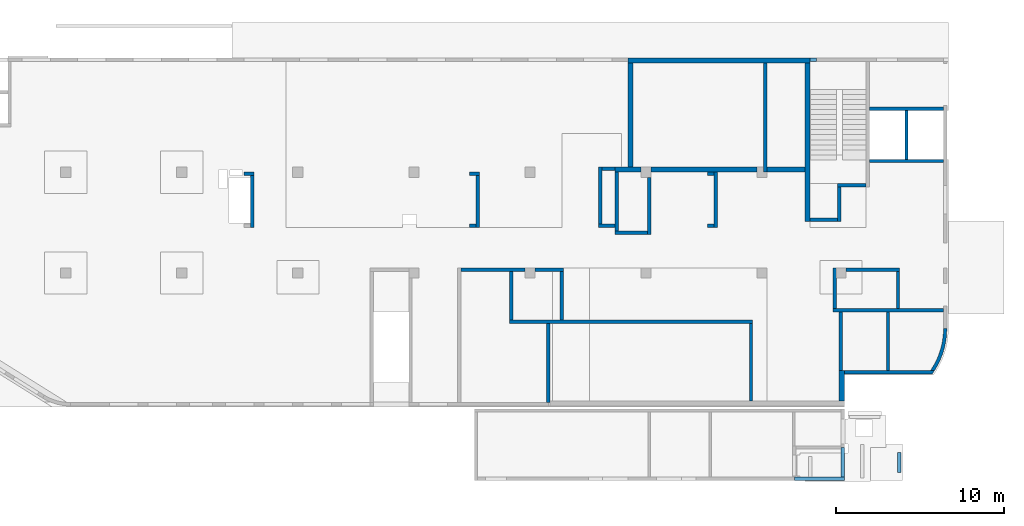
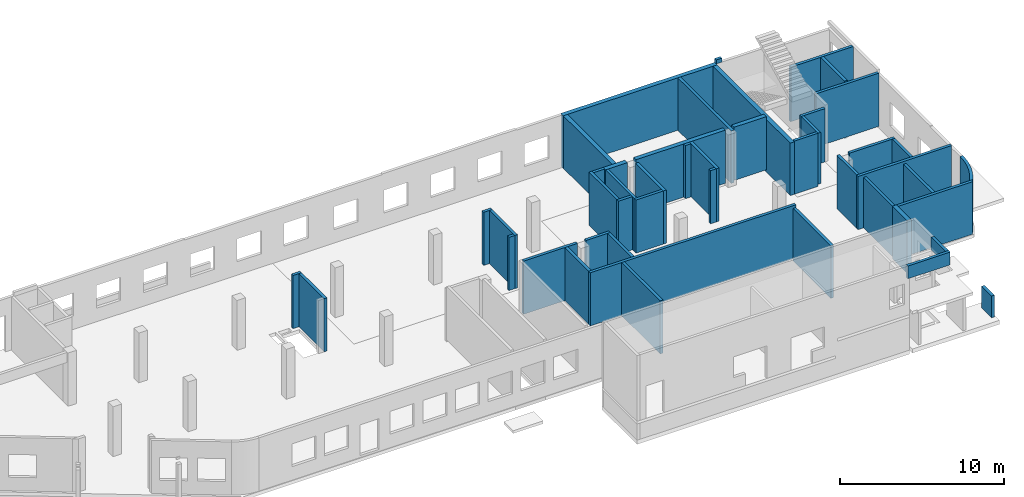
# One storey, part 3 of 8: 47 walls.
"""IFC4 building model written with IfcOpenShell, lengths in millimetres."""

from ifc_helpers import new_model, entity, si_unit, converted_unit, derived_unit, direction, frame, origin, place, context, subcontext, project, spatial, indexed_curve, outline, extrude, material, type_object, element, save


model = new_model("IFC4")

# Units and contexts
model_context = context("Model", 3, precision=0.01, world=origin(), true_north=direction((6.12303176911189e-17, 1.0)))
plan_context = context("Plan", 3, precision=0.01, world=origin(), true_north=direction((6.12303176911189e-17, 1.0)))
body_context = subcontext(model_context, "Body", "Model", "MODEL_VIEW")
ifc_project = project(units=[si_unit("LENGTHUNIT", "METRE", prefix="MILLI"), si_unit("AREAUNIT", "SQUARE_METRE"), si_unit("VOLUMEUNIT", "CUBIC_METRE"), converted_unit("PLANEANGLEUNIT", "DEGREE", entity("IfcRatioMeasure", 0.0174532925199433), si_unit("PLANEANGLEUNIT", "RADIAN"), dimensions=[0, 0, 0, 0, 0, 0, 0]), si_unit("MASSUNIT", "GRAM", prefix="KILO"), derived_unit("MASSDENSITYUNIT", [(si_unit("MASSUNIT", "GRAM", prefix="KILO"), 1), (si_unit("LENGTHUNIT", "METRE"), -3)]), derived_unit("MOMENTOFINERTIAUNIT", [(si_unit("LENGTHUNIT", "METRE"), 4)]), si_unit("TIMEUNIT", "SECOND"), si_unit("FREQUENCYUNIT", "HERTZ"), si_unit("THERMODYNAMICTEMPERATUREUNIT", "DEGREE_CELSIUS"), derived_unit("THERMALTRANSMITTANCEUNIT", [(si_unit("MASSUNIT", "GRAM", prefix="KILO"), 1), (si_unit("THERMODYNAMICTEMPERATUREUNIT", "KELVIN"), -1), (si_unit("TIMEUNIT", "SECOND"), -3)]), derived_unit("VOLUMETRICFLOWRATEUNIT", [(si_unit("LENGTHUNIT", "METRE"), 3), (si_unit("TIMEUNIT", "SECOND"), -1)]), derived_unit("MASSFLOWRATEUNIT", [(si_unit("MASSUNIT", "GRAM", prefix="KILO"), 1), (si_unit("TIMEUNIT", "SECOND"), -1)]), derived_unit("ROTATIONALFREQUENCYUNIT", [(si_unit("TIMEUNIT", "SECOND"), -1)]), si_unit("ELECTRICCURRENTUNIT", "AMPERE"), si_unit("ELECTRICVOLTAGEUNIT", "VOLT"), si_unit("POWERUNIT", "WATT"), si_unit("FORCEUNIT", "NEWTON", prefix="KILO"), si_unit("ILLUMINANCEUNIT", "LUX"), si_unit("LUMINOUSFLUXUNIT", "LUMEN"), si_unit("LUMINOUSINTENSITYUNIT", "CANDELA"), derived_unit("USERDEFINED", [(si_unit("MASSUNIT", "GRAM", prefix="KILO"), -1), (si_unit("LENGTHUNIT", "METRE"), -2), (si_unit("TIMEUNIT", "SECOND"), 3), (si_unit("LUMINOUSFLUXUNIT", "LUMEN"), 1)]), derived_unit("LINEARVELOCITYUNIT", [(si_unit("LENGTHUNIT", "METRE"), 1), (si_unit("TIMEUNIT", "SECOND"), -1)]), si_unit("PRESSUREUNIT", "PASCAL"), derived_unit("USERDEFINED", [(si_unit("LENGTHUNIT", "METRE"), -2), (si_unit("MASSUNIT", "GRAM", prefix="KILO"), 1), (si_unit("TIMEUNIT", "SECOND"), -2)]), derived_unit("LINEARFORCEUNIT", [(si_unit("MASSUNIT", "GRAM", prefix="KILO"), 1), (si_unit("LENGTHUNIT", "METRE"), 1), (si_unit("TIMEUNIT", "SECOND"), -2), (si_unit("LENGTHUNIT", "METRE"), -1)]), derived_unit("PLANARFORCEUNIT", [(si_unit("MASSUNIT", "GRAM", prefix="KILO"), 1), (si_unit("LENGTHUNIT", "METRE"), 1), (si_unit("TIMEUNIT", "SECOND"), -2), (si_unit("LENGTHUNIT", "METRE"), -2)])], contexts=[model_context, plan_context])

# Site, building, storey
site_placement = place(None, origin())
site = spatial("IfcSite", under=ifc_project, at=site_placement, CompositionType="ELEMENT")
building_placement = place(site_placement, origin())
building = spatial("IfcBuilding", under=site, at=building_placement, CompositionType="ELEMENT")
storey_placement = place(building_placement, origin())
storey = spatial("IfcBuildingStorey", under=building, at=storey_placement, Name="01", CompositionType="ELEMENT", Elevation=0.0)

# Walls
ifc_material = material()
wall_type_1 = type_object("IfcWallType", Name=":ADSK_ 25_200", PredefinedType="STANDARD")
wall_1_placement = place(storey_placement, frame((48470.0, 7900.0, 0.0), z_axis=(0.0, 0.0, 1.0), x_axis=(-1.0, 0.0, 0.0)))
element("IfcWall", 1, at=wall_1_placement, inside=storey, type_object=wall_type_1, material=ifc_material, Name=":ADSK_ 25_200", ObjectType=":ADSK_ 25_200", PredefinedType="NOTDEFINED", context=body_context, shape_type="SweptSolid", body=[
    extrude(outline(indexed_curve([(3800.0, 100.0), (-3.42426881021964e-13, 100.0), (3.42426881021964e-13, -100.0), (3800.0, -100.0), (3800.0, 100.0)], self_intersect=False)), origin(), (0.0, 0.0, 1.0), 3950.0),
])
wall_2_placement = place(storey_placement, frame((49070.0, 7900.0, 0.0)))
element("IfcWall", 2, at=wall_2_placement, inside=storey, type_object=wall_type_1, material=ifc_material, Name=":ADSK_ 25_200", ObjectType=":ADSK_ 25_200", PredefinedType="NOTDEFINED", context=body_context, shape_type="SweptSolid", body=[
    extrude(outline(indexed_curve([(1700.0, 100.0), (-3.18490332146586e-13, 100.0), (3.18490332146586e-13, -100.0), (1700.0, -100.0), (1700.0, 100.0)], self_intersect=False)), origin(), (0.0, 0.0, 1.0), 3950.0),
])
wall_3_placement = place(storey_placement, frame((50670.0, 7800.0, 0.0), z_axis=(0.0, 0.0, 1.0), x_axis=(0.0, -1.0, 0.0)))
element("IfcWall", 3, at=wall_3_placement, inside=storey, type_object=wall_type_1, material=ifc_material, Name=":ADSK_ 25_200", ObjectType=":ADSK_ 25_200", PredefinedType="NOTDEFINED", context=body_context, shape_type="SweptSolid", body=[
    extrude(outline(indexed_curve([(2899.99999999996, 100.000000000003), (0.0, 100.000000000003), (0.0, -100.000000000003), (2899.99999999996, -100.000000000003), (2899.99999999996, 100.000000000003)], self_intersect=False)), origin(), (0.0, 0.0, 1.0), 3950.0),
])
wall_4_placement = place(storey_placement, frame((62020.0, 4800.0, 0.0), z_axis=(0.0, 0.0, 1.0), x_axis=(-1.0, 0.0, 0.0)))
element("IfcWall", 4, at=wall_4_placement, inside=storey, type_object=wall_type_1, material=ifc_material, Name=":ADSK_ 25_200", ObjectType=":ADSK_ 25_200", PredefinedType="NOTDEFINED", context=body_context, shape_type="SweptSolid", body=[
    extrude(outline(indexed_curve([(14450.0, 99.9999999999999), (-3.06338005499363e-13, 100.0), (3.06338005499363e-13, -100.0), (14450.0, -100.0), (14450.0, 99.9999999999999)], self_intersect=False)), origin(), (0.0, 0.0, 1.0), 3950.0),
])
wall_5_placement = place(storey_placement, frame((47670.0, 7800.0, 0.0), z_axis=(0.0, 0.0, 1.0), x_axis=(0.0, -1.0, 0.0)))
element("IfcWall", 5, at=wall_5_placement, inside=storey, type_object=wall_type_1, material=ifc_material, Name=":ADSK_ 25_200", ObjectType=":ADSK_ 25_200", PredefinedType="NOTDEFINED", context=body_context, shape_type="SweptSolid", body=[
    extrude(outline(indexed_curve([(2899.99999999996, 100.000000000003), (0.0, 100.000000000003), (0.0, -100.000000000003), (2899.99999999996, -100.000000000003), (2899.99999999996, 100.000000000003)], self_intersect=False)), origin(), (0.0, 0.0, 1.0), 3950.0),
])
wall_6_placement = place(storey_placement, frame((49870.0, 0.0, 0.0), z_axis=(0.0, 0.0, 1.0), x_axis=(0.0, 1.0, 0.0)))
element("IfcWall", 6, at=wall_6_placement, inside=storey, type_object=wall_type_1, material=ifc_material, Name=":ADSK_ 25_200", ObjectType=":ADSK_ 25_200", PredefinedType="NOTDEFINED", context=body_context, shape_type="SweptSolid", body=[
    extrude(outline(indexed_curve([(4699.99999999994, 99.9999999999998), (3.10976382565532e-20, 100.000000000003), (-3.10976382565532e-20, -100.000000000003), (4699.99999999994, -100.000000000007), (4699.99999999994, 99.9999999999998)], self_intersect=False)), origin(), (0.0, 0.0, 1.0), 3950.0),
])
wall_7_placement = place(storey_placement, frame((61920.0, 4700.0, -150.0), z_axis=(0.0, 0.0, 1.0), x_axis=(0.0, -1.0, 0.0)))
element("IfcWall", 7, at=wall_7_placement, inside=storey, type_object=wall_type_1, material=ifc_material, Name=":ADSK_ 25_200", ObjectType=":ADSK_ 25_200", PredefinedType="NOTDEFINED", context=body_context, shape_type="SweptSolid", body=[
    extrude(outline(indexed_curve([(4599.99999999994, 100.000000000006), (-2.40637139844096e-13, 100.000000000003), (2.40637139844096e-13, -100.000000000003), (4599.99999999994, -100.000000000001), (4599.99999999994, 100.000000000006)], self_intersect=False)), origin(), (0.0, 0.0, 1.0), 3900.0),
])
wall_8_placement = place(storey_placement, frame((67270.0, 1795.0, 0.0), z_axis=(0.0, 0.0, 1.0), x_axis=(0.0, 1.0, 0.0)))
element("IfcWall", 8, at=wall_8_placement, inside=storey, type_object=wall_type_1, material=ifc_material, Name=":ADSK_ 25_200", ObjectType=":ADSK_ 25_200", PredefinedType="NOTDEFINED", context=body_context, shape_type="SweptSolid", body=[
    extrude(outline(indexed_curve([(3604.99999999987, 100.000000000006), (-4.66276854653109e-14, 100.000000000003), (4.66276854653109e-14, -100.000000000003), (3604.99999999987, -100.0), (3604.99999999987, 100.000000000006)], self_intersect=False)), origin(), (0.0, 0.0, 1.0), 3750.0),
])
wall_9_placement = place(storey_placement, frame((67370.0, 1795.0, -150.0)))
element("IfcWall", 9, at=wall_9_placement, inside=storey, type_object=wall_type_1, material=ifc_material, Name=":ADSK_ 25_200", ObjectType=":ADSK_ 25_200", PredefinedType="NOTDEFINED", context=body_context, shape_type="SweptSolid", body=[
    extrude(outline(indexed_curve([(5320.61392813742, -100.000000000023), (5334.83556171488, -80.3298207855378), (5348.9532041316, -60.584872456016), (5362.96646230287, -40.7657047800855), (5376.87494605046, -20.8728695928891), (5390.67826811337, -0.906920780744112), (5404.3760441587, 19.1315857343014), (5417.96789279233, 39.2420920099402), (5431.45343556949, 59.4240380991268), (5444.83229700539, 79.6768620656952), (5458.10410458558, 99.999999999978), (5217.31502339911, 100.0), (99.9999999999943, 100.0), (99.9999999999949, -100.0), (5320.61392813742, -100.000000000023)], self_intersect=False)), origin(), (0.0, 0.0, 1.0), 3900.0),
])
wall_10_placement = place(storey_placement, frame((66795.0, 5500.0, 0.0)))
element("IfcWall", 10, at=wall_10_placement, inside=storey, type_object=wall_type_1, material=ifc_material, Name=":ADSK_ 25_200", ObjectType=":ADSK_ 25_200", PredefinedType="NOTDEFINED", context=body_context, shape_type="SweptSolid", body=[
    extrude(outline(indexed_curve([(6575.0002685548, 100.000000000001), (-3.21116670446023e-13, 100.0), (3.21116670446023e-13, -100.0), (6575.0002685548, -99.9999999999995), (6575.0002685548, 100.000000000001)], self_intersect=False)), origin(), (0.0, 0.0, 1.0), 3950.0),
])
wall_11_placement = place(storey_placement, frame((73470.0, 4400.0, -150.0)))
element("IfcWall", 11, at=wall_11_placement, inside=storey, type_object=wall_type_1, material=ifc_material, Name=":ADSK_ 25_200", ObjectType=":ADSK_ 25_200", PredefinedType="NOTDEFINED", context=body_context, shape_type="SweptSolid", body=[
    extrude(outline(indexed_curve([(-641.895895414368, -2504.99990750277), (-504.115533634932, -2278.7932507463), (-379.582920453029, -2045.03160310687), (-268.710923968226, -1804.489964199), (-171.867122675117, -1557.96581162138), (-89.3725868152551, -1306.27645704658), (-21.500813919721, -1050.25633655401), (31.5231779285028, -790.754244189626), (69.5235961062065, -528.630517924081), (92.3744562625127, -264.754187338847), (99.9999999999513, -9.2496628161598e-05), (-99.9999999999599, 9.24965686039059e-05), (-108.068327086898, -266.334566127823), (-132.243226652315, -531.692480118633), (-172.436042031252, -795.100501785527), (-228.499374019115, -1055.59263428279), (-300.227621429127, -1312.21357421178), (-387.357735094033, -1564.02221500731), (-489.570182546934, -1810.0950982599), (-606.490119843403, -2049.52980031693), (-737.688766227591, -2281.44824174303), (-882.684976600846, -2504.99990750275), (-641.895895414368, -2504.99990750277)], self_intersect=False)), origin(), (0.0, 0.0, 1.0), 3900.0),
])
wall_12_placement = place(storey_placement, frame((66895.0, 8000.0, 0.0), z_axis=(0.0, 0.0, 1.0), x_axis=(0.0, -1.0, 0.0)))
element("IfcWall", 12, at=wall_12_placement, inside=storey, type_object=wall_type_1, material=ifc_material, Name=":ADSK_ 25_200", ObjectType=":ADSK_ 25_200", PredefinedType="NOTDEFINED", context=body_context, shape_type="SweptSolid", body=[
    extrude(outline(indexed_curve([(2400.0000000002, 100.000000000003), (0.0, 100.000000000003), (0.0, -100.000000000003), (2400.0000000002, -100.000000000003), (2400.0000000002, 100.000000000003)], self_intersect=False)), origin(), (0.0, 0.0, 1.0), 3950.0),
])
wall_13_placement = place(storey_placement, frame((67570.0, 7900.0, 0.0)))
element("IfcWall", 13, at=wall_13_placement, inside=storey, type_object=wall_type_1, material=ifc_material, Name=":ADSK_ 25_200", ObjectType=":ADSK_ 25_200", PredefinedType="NOTDEFINED", context=body_context, shape_type="SweptSolid", body=[
    extrude(outline(indexed_curve([(3200.0, 99.9999999999998), (-3.30452149995528e-13, 100.0), (3.30452149995528e-13, -100.0), (3200.0, -100.0), (3200.0, 99.9999999999998)], self_intersect=False)), origin(), (0.0, 0.0, 1.0), 3950.0),
])
wall_14_placement = place(storey_placement, frame((70670.0, 7800.0, 0.0), z_axis=(0.0, 0.0, 1.0), x_axis=(0.0, -1.0, 0.0)))
element("IfcWall", 14, at=wall_14_placement, inside=storey, type_object=wall_type_1, material=ifc_material, Name=":ADSK_ 25_200", ObjectType=":ADSK_ 25_200", PredefinedType="NOTDEFINED", context=body_context, shape_type="SweptSolid", body=[
    extrude(outline(indexed_curve([(2200.0000000002, 100.000000000003), (0.0, 100.000000000003), (0.0, -100.000000000003), (2200.0000000002, -100.000000000003), (2200.0000000002, 100.000000000003)], self_intersect=False)), origin(), (0.0, 0.0, 1.0), 3950.0),
])
wall_15_placement = place(storey_placement, frame((71170.0, 17370.0, -250.0), z_axis=(0.0, 0.0, 1.0), x_axis=(0.0, -1.0, 0.0)))
element("IfcWall", 15, at=wall_15_placement, inside=storey, type_object=wall_type_1, material=ifc_material, Name=":ADSK_ 25_200", ObjectType=":ADSK_ 25_200", PredefinedType="NOTDEFINED", context=body_context, shape_type="SweptSolid", body=[
    extrude(outline(indexed_curve([(2899.9999999995, 100.000000000003), (-2.98721966703065e-13, 100.000000000003), (2.98721966703065e-13, -100.000000000003), (2899.99999999951, -100.000000000003), (2899.9999999995, 100.000000000003)], self_intersect=False)), origin(), (0.0, 0.0, 1.0), 4300.0),
])
wall_16_placement = place(storey_placement, frame((73370.0, 14370.0, 0.0), z_axis=(0.0, 0.0, 1.0), x_axis=(-1.0, 0.0, 0.0)))
element("IfcWall", 16, at=wall_16_placement, inside=storey, type_object=wall_type_1, material=ifc_material, Name=":ADSK_ 25_200", ObjectType=":ADSK_ 25_200", PredefinedType="NOTDEFINED", context=body_context, shape_type="SweptSolid", body=[
    extrude(outline(indexed_curve([(4400.00000000001, 99.9999999999983), (-3.30182467507706e-13, 99.9999999999989), (3.30182467507706e-13, -99.9999999999989), (4400.00000000001, -99.9999999999995), (4400.00000000001, 99.9999999999983)], self_intersect=False)), origin(), (0.0, 0.0, 1.0), 3950.0),
])
wall_17_placement = place(storey_placement, frame((73370.0, 17470.0, 0.0), z_axis=(0.0, 0.0, 1.0), x_axis=(-1.0, 0.0, 0.0)))
element("IfcWall", 17, at=wall_17_placement, inside=storey, type_object=wall_type_1, material=ifc_material, Name=":ADSK_ 25_200", ObjectType=":ADSK_ 25_200", PredefinedType="NOTDEFINED", context=body_context, shape_type="SweptSolid", body=[
    extrude(outline(indexed_curve([(4400.00000000001, 99.9999999999983), (-3.29568256742984e-13, 99.9999999999989), (3.29568256742984e-13, -99.9999999999989), (4400.00000000001, -99.9999999999996), (4400.00000000001, 99.9999999999983)], self_intersect=False)), origin(), (0.0, 0.0, 1.0), 4050.0),
])
wall_18_placement = place(storey_placement, frame((68770.0, 12930.0, -150.0), z_axis=(0.0, 0.0, 1.0), x_axis=(-1.0, 0.0, 0.0)))
element("IfcWall", 18, at=wall_18_placement, inside=storey, type_object=wall_type_1, material=ifc_material, Name=":ADSK_ 25_200", ObjectType=":ADSK_ 25_200", PredefinedType="NOTDEFINED", context=body_context, shape_type="SweptSolid", body=[
    extrude(outline(indexed_curve([(1689.99999999999, 99.9999999999992), (-3.99213688220603e-13, 99.9999999999989), (3.99213688220603e-13, -99.9999999999989), (1689.99999999999, -99.9999999999987), (1689.99999999999, 99.9999999999992)], self_intersect=False)), origin(), (0.0, 0.0, 1.0), 3950.0),
])
wall_19_placement = place(storey_placement, frame((67180.0, 10783.78, 0.0), z_axis=(0.0, 0.0, 1.0), x_axis=(0.0, 1.0, 0.0)))
element("IfcWall", 19, at=wall_19_placement, inside=storey, type_object=wall_type_1, material=ifc_material, Name=":ADSK_ 25_200", ObjectType=":ADSK_ 25_200", PredefinedType="NOTDEFINED", context=body_context, shape_type="SweptSolid", body=[
    extrude(outline(indexed_curve([(2046.22139317037, 100.000000000003), (0.0, 100.000000000003), (0.0, -100.000000000003), (2046.22139317037, -100.000000000003), (2046.22139317037, 100.000000000003)], self_intersect=False)), origin(), (0.0, 0.0, 1.0), 3800.0),
])
wall_20_placement = place(storey_placement, frame((67080.0, 10883.78, -150.0), z_axis=(0.0, 0.0, 1.0), x_axis=(-1.0, 0.0, 0.0)))
element("IfcWall", 20, at=wall_20_placement, inside=storey, type_object=wall_type_1, material=ifc_material, Name=":ADSK_ 25_200", ObjectType=":ADSK_ 25_200", PredefinedType="NOTDEFINED", context=body_context, shape_type="SweptSolid", body=[
    extrude(outline(indexed_curve([(1650.0, 99.9999999999989), (-2.62513243466275e-13, 99.9999999999989), (2.62513243466275e-13, -99.9999999999989), (1650.0, -99.9999999999989), (1650.0, 99.9999999999989)], self_intersect=False)), origin(), (0.0, 0.0, 1.0), 3950.0),
])
wall_21_placement = place(storey_placement, frame((62770.0, 13700.0, -150.0), z_axis=(0.0, 0.0, 1.0), x_axis=(0.0, 1.0, 0.0)))
element("IfcWall", 21, at=wall_21_placement, inside=storey, type_object=wall_type_1, material=ifc_material, Name=":ADSK_ 25_200", ObjectType=":ADSK_ 25_200", PredefinedType="NOTDEFINED", context=body_context, shape_type="SweptSolid", body=[
    extrude(outline(indexed_curve([(6499.99999999978, 100.000000000003), (0.0, 100.000000000003), (0.0, -100.000000000003), (6499.99999999978, -100.000000000003), (6499.99999999978, 100.000000000003)], self_intersect=False)), origin(), (0.0, 0.0, 1.0), 3900.0),
])
wall_22_placement = place(storey_placement, frame((55870.0, 13400.0, 0.0), z_axis=(0.0, 0.0, 1.0), x_axis=(0.0, -1.0, 0.0)))
element("IfcWall", 22, at=wall_22_placement, inside=storey, type_object=wall_type_1, material=ifc_material, Name=":ADSK_ 25_200", ObjectType=":ADSK_ 25_200", PredefinedType="NOTDEFINED", context=body_context, shape_type="SweptSolid", body=[
    extrude(outline(indexed_curve([(3400.0, 100.000000000003), (-1.27396132858709e-13, 100.000000000003), (1.27396132858709e-13, -100.000000000003), (3400.0, -100.000000000003), (3400.0, 100.000000000003)], self_intersect=False)), origin(), (0.0, 0.0, 1.0), 3950.0),
])
wall_23_placement = place(storey_placement, frame((55770.0, 10100.0, 0.0), z_axis=(0.0, 0.0, 1.0), x_axis=(-1.0, 0.0, 0.0)))
element("IfcWall", 23, at=wall_23_placement, inside=storey, type_object=wall_type_1, material=ifc_material, Name=":ADSK_ 25_200", ObjectType=":ADSK_ 25_200", PredefinedType="NOTDEFINED", context=body_context, shape_type="SweptSolid", body=[
    extrude(outline(indexed_curve([(1940.00000000001, 99.9999999999985), (-3.10870946210073e-13, 99.9999999999989), (3.10870946210073e-13, -99.9999999999989), (1940.00000000001, -99.9999999999994), (1940.00000000001, 99.9999999999985)], self_intersect=False)), origin(), (0.0, 0.0, 1.0), 3950.0),
])
wall_24_placement = place(storey_placement, frame((59830.0, 13700.0, 0.0), z_axis=(0.0, 0.0, 1.0), x_axis=(0.0, -1.0, 0.0)))
element("IfcWall", 24, at=wall_24_placement, inside=storey, type_object=wall_type_1, material=ifc_material, Name=":ADSK_ 25_200", ObjectType=":ADSK_ 25_200", PredefinedType="NOTDEFINED", context=body_context, shape_type="SweptSolid", body=[
    extrude(outline(indexed_curve([(3275.00000000016, 100.000000000003), (-2.64517161355341e-13, 100.000000000003), (2.64517161355341e-13, -100.000000000003), (3275.00000000016, -100.000000000003), (3275.00000000016, 100.000000000003)], self_intersect=False)), origin(), (0.0, 0.0, 1.0), 3950.0),
])
wall_25_placement = place(storey_placement, frame((59730.0, 10525.0, 0.0), z_axis=(0.0, 0.0, 1.0), x_axis=(-1.0, 0.0, 0.0)))
element("IfcWall", 25, at=wall_25_placement, inside=storey, type_object=wall_type_1, material=ifc_material, Name=":ADSK_ 25_200", ObjectType=":ADSK_ 25_200", PredefinedType="NOTDEFINED", context=body_context, shape_type="SweptSolid", body=[
    extrude(outline(indexed_curve([(400.000000000013, 99.9999999999982), (-3.6095570976612e-13, 99.9999999999989), (3.6095570976612e-13, -99.9999999999989), (400.000000000013, -99.9999999999996), (400.000000000013, 99.9999999999982)], self_intersect=False)), origin(), (0.0, 0.0, 1.0), 3950.0),
])
wall_26_placement = place(storey_placement, frame((59330.0, 13600.0, 0.0)))
element("IfcWall", 26, at=wall_26_placement, inside=storey, type_object=wall_type_1, material=ifc_material, Name=":ADSK_ 25_200", ObjectType=":ADSK_ 25_200", PredefinedType="NOTDEFINED", context=body_context, shape_type="SweptSolid", body=[
    extrude(outline(indexed_curve([(400.000000000003, 99.9999999999989), (-1.08286712929837e-12, 99.9999999999989), (1.08286712929837e-12, -99.9999999999989), (400.000000000005, -99.9999999999989), (400.000000000003, 99.9999999999989)], self_intersect=False)), origin(), (0.0, 0.0, 1.0), 3950.0),
])
wall_27_placement = place(storey_placement, frame((53930.0, 10200.0, 0.0), z_axis=(0.0, 0.0, 1.0), x_axis=(0.0, 1.0, 0.0)))
element("IfcWall", 27, at=wall_27_placement, inside=storey, type_object=wall_type_1, material=ifc_material, Name=":ADSK_ 25_200", ObjectType=":ADSK_ 25_200", PredefinedType="NOTDEFINED", context=body_context, shape_type="SweptSolid", body=[
    extrude(outline(indexed_curve([(3500.0, 100.000000000003), (0.0, 100.000000000003), (0.0, -100.000000000003), (3500.0, -100.000000000003), (3500.0, 100.000000000003)], self_intersect=False)), origin(), (0.0, 0.0, 1.0), 3950.0),
])
wall_28_placement = place(storey_placement, frame((53830.0, 10525.0, 0.0), z_axis=(0.0, 0.0, 1.0), x_axis=(-1.0, 0.0, 0.0)))
element("IfcWall", 28, at=wall_28_placement, inside=storey, type_object=wall_type_1, material=ifc_material, Name=":ADSK_ 25_200", ObjectType=":ADSK_ 25_200", PredefinedType="NOTDEFINED", context=body_context, shape_type="SweptSolid", body=[
    extrude(outline(indexed_curve([(979.999999999994, 99.9999999999989), (0.0, 99.9999999999989), (0.0, -99.9999999999989), (979.999999999994, -99.9999999999989), (979.999999999994, 99.9999999999989)], self_intersect=False)), origin(), (0.0, 0.0, 1.0), 3950.0),
])
wall_29_placement = place(storey_placement, frame((52950.0, 10625.0, 0.0), z_axis=(0.0, 0.0, 1.0), x_axis=(0.0, 1.0, 0.0)))
element("IfcWall", 29, at=wall_29_placement, inside=storey, type_object=wall_type_1, material=ifc_material, Name=":ADSK_ 25_200", ObjectType=":ADSK_ 25_200", PredefinedType="NOTDEFINED", context=body_context, shape_type="SweptSolid", body=[
    extrude(outline(indexed_curve([(3375.00000000001, 100.000000000003), (0.0, 100.000000000003), (0.0, -100.000000000003), (3375.00000000001, -100.000000000003), (3375.00000000001, 100.000000000003)], self_intersect=False)), origin(), (0.0, 0.0, 1.0), 3950.0),
])
wall_30_placement = place(storey_placement, frame((53830.0, 13900.0, 0.0), z_axis=(0.0, 0.0, 1.0), x_axis=(-1.0, 0.0, 0.0)))
element("IfcWall", 30, at=wall_30_placement, inside=storey, type_object=wall_type_1, material=ifc_material, Name=":ADSK_ 25_200", ObjectType=":ADSK_ 25_200", PredefinedType="NOTDEFINED", context=body_context, shape_type="SweptSolid", body=[
    extrude(outline(indexed_curve([(779.999999999996, 99.9999999999991), (-2.96675925835205e-13, 99.9999999999989), (2.96675925835205e-13, -99.9999999999989), (779.999999999996, -99.9999999999988), (779.999999999996, 99.9999999999991)], self_intersect=False)), origin(), (0.0, 0.0, 1.0), 3950.0),
])
wall_31_placement = place(storey_placement, frame((45170.0, 13600.0, 0.0)))
element("IfcWall", 31, at=wall_31_placement, inside=storey, type_object=wall_type_1, material=ifc_material, Name=":ADSK_ 25_200", ObjectType=":ADSK_ 25_200", PredefinedType="NOTDEFINED", context=body_context, shape_type="SweptSolid", body=[
    extrude(outline(indexed_curve([(600.000000000002, 99.9999999999989), (-3.60955709766126e-13, 99.9999999999989), (3.60955709766126e-13, -99.9999999999989), (600.000000000003, -99.9999999999989), (600.000000000002, 99.9999999999989)], self_intersect=False)), origin(), (0.0, 0.0, 1.0), 3950.0),
])
wall_32_placement = place(storey_placement, frame((45670.0, 13500.0, 0.0), z_axis=(0.0, 0.0, 1.0), x_axis=(0.0, -1.0, 0.0)))
element("IfcWall", 32, at=wall_32_placement, inside=storey, type_object=wall_type_1, material=ifc_material, Name=":ADSK_ 25_200", ObjectType=":ADSK_ 25_200", PredefinedType="NOTDEFINED", context=body_context, shape_type="SweptSolid", body=[
    extrude(outline(indexed_curve([(3075.0, 100.000000000003), (-2.81721529573577e-13, 100.000000000003), (2.81721529573577e-13, -100.000000000003), (3075.0, -100.000000000003), (3075.0, 100.000000000003)], self_intersect=False)), origin(), (0.0, 0.0, 1.0), 3950.0),
])
wall_33_placement = place(storey_placement, frame((45570.0, 10525.0, 0.0), z_axis=(0.0, 0.0, 1.0), x_axis=(-1.0, 0.0, 0.0)))
element("IfcWall", 33, at=wall_33_placement, inside=storey, type_object=wall_type_1, material=ifc_material, Name=":ADSK_ 25_200", ObjectType=":ADSK_ 25_200", PredefinedType="NOTDEFINED", context=body_context, shape_type="SweptSolid", body=[
    extrude(outline(indexed_curve([(399.999999999995, 100.0), (-3.60955709766139e-13, 100.000000000001), (3.60955709766139e-13, -100.000000000001), (399.999999999996, -100.000000000002), (399.999999999995, 100.0)], self_intersect=False)), origin(), (0.0, 0.0, 1.0), 3950.0),
])
wall_34_placement = place(storey_placement, frame((31770.0, 13600.0, 0.0)))
element("IfcWall", 34, at=wall_34_placement, inside=storey, type_object=wall_type_1, material=ifc_material, Name=":ADSK_ 25_200", ObjectType=":ADSK_ 25_200", PredefinedType="NOTDEFINED", context=body_context, shape_type="SweptSolid", body=[
    extrude(outline(indexed_curve([(599.999999999993, 99.9999999999989), (-3.60955709766126e-13, 99.9999999999989), (3.60955709766126e-13, -99.9999999999989), (599.999999999994, -99.9999999999989), (599.999999999993, 99.9999999999989)], self_intersect=False)), origin(), (0.0, 0.0, 1.0), 3950.0),
])
wall_35_placement = place(storey_placement, frame((32270.0, 13500.0, 0.0), z_axis=(0.0, 0.0, 1.0), x_axis=(0.0, -1.0, 0.0)))
element("IfcWall", 35, at=wall_35_placement, inside=storey, type_object=wall_type_1, material=ifc_material, Name=":ADSK_ 25_200", ObjectType=":ADSK_ 25_200", PredefinedType="NOTDEFINED", context=body_context, shape_type="SweptSolid", body=[
    extrude(outline(indexed_curve([(3075.0, 99.9999999999989), (-2.81721529573565e-13, 99.9999999999989), (2.81721529573565e-13, -99.9999999999989), (3075.0, -99.9999999999989), (3075.0, 99.9999999999989)], self_intersect=False)), origin(), (0.0, 0.0, 1.0), 3950.0),
])
wall_36_placement = place(storey_placement, frame((65430.0, 20400.0, 3750.0)))
element("IfcWall", 36, at=wall_36_placement, inside=storey, type_object=wall_type_1, material=ifc_material, Name=":ADSK_ 25_200", ObjectType=":ADSK_ 25_200", PredefinedType="NOTDEFINED", context=body_context, shape_type="SweptSolid", body=[
    extrude(outline(indexed_curve([(400.000000000048, 99.9999999999989), (0.0, 99.9999999999989), (0.0, -99.9999999999989), (400.000000000048, -99.9999999999989), (400.000000000048, 99.9999999999989)], self_intersect=False)), origin(), (0.0, 0.0, 1.0), 299.999999999999),
])
wall_37_placement = place(storey_placement, frame((70070.0, 1895.0, 0.0), z_axis=(0.0, 0.0, 1.0), x_axis=(0.0, 1.0, 0.0)))
element("IfcWall", 37, at=wall_37_placement, inside=storey, type_object=wall_type_1, material=ifc_material, Name=":ADSK_ 25_200", ObjectType=":ADSK_ 25_200", PredefinedType="NOTDEFINED", context=body_context, shape_type="SweptSolid", body=[
    extrude(outline(indexed_curve([(3504.99999999987, 100.000000000006), (-4.66276854653109e-14, 100.000000000003), (4.66276854653109e-14, -100.000000000003), (3504.99999999987, -100.000000000001), (3504.99999999987, 100.000000000006)], self_intersect=False)), origin(), (0.0, 0.0, 1.0), 3750.0),
])
wall_38_placement = place(storey_placement, frame((64500.0, -4520.0, 3230.0)))
element("IfcWall", 38, at=wall_38_placement, inside=storey, type_object=wall_type_1, material=ifc_material, Name=":ADSK_ 25_200", ObjectType=":ADSK_ 25_200", PredefinedType="NOTDEFINED", context=body_context, shape_type="SweptSolid", body=[
    extrude(outline(indexed_curve([(2969.99665167066, 100.0), (-3.32288148921946e-13, 100.0), (3.32288148921946e-13, -100.0), (2969.99665167066, -99.9999999999999), (2969.99665167066, 100.0)], self_intersect=False)), origin(), (0.0, 0.0, 1.0), 950.000000000001),
])
wall_39_placement = place(storey_placement, frame((67370.0, -4420.0, 3230.0), z_axis=(0.0, 0.0, 1.0), x_axis=(0.0, 1.0, 0.0)))
element("IfcWall", 39, at=wall_39_placement, inside=storey, type_object=wall_type_1, material=ifc_material, Name=":ADSK_ 25_200", ObjectType=":ADSK_ 25_200", PredefinedType="NOTDEFINED", context=body_context, shape_type="SweptSolid", body=[
    extrude(outline(indexed_curve([(1750.00007018598, 100.000000000003), (0.0, 100.000000000003), (0.0, -100.000000000003), (1750.00007018598, -100.000000000003), (1750.00007018598, 100.000000000003)], self_intersect=False)), origin(), (0.0, 0.0, 1.0), 950.000000000001),
])
wall_40_placement = place(storey_placement, frame((70745.13, -4154.59, -2100.0), z_axis=(0.0, 0.0, 1.0), x_axis=(0.0, 1.0, 0.0)))
element("IfcWall", 40, at=wall_40_placement, inside=storey, type_object=wall_type_1, material=ifc_material, Name=":ADSK_ 25_200", ObjectType=":ADSK_ 25_200", PredefinedType="NOTDEFINED", context=body_context, shape_type="SweptSolid", body=[
    extrude(outline(indexed_curve([(1200.0, 100.000000000003), (0.0, 100.000000000003), (0.0, -100.000000000003), (1200.0, -100.000000000003), (1200.0, 100.000000000003)], self_intersect=False)), origin(), (0.0, 0.0, 1.0), 1620.0),
])
wall_type_2 = type_object("IfcWallType", Name=":ADSK_ 25_300", PredefinedType="STANDARD")
wall_41_placement = place(storey_placement, frame((67320.0, 1895.0, -150.0), z_axis=(0.0, 0.0, 1.0), x_axis=(0.0, -1.0, 0.0)))
element("IfcWall", 41, at=wall_41_placement, inside=storey, type_object=wall_type_2, material=ifc_material, Name=":ADSK_ 25_300", ObjectType=":ADSK_ 25_300", PredefinedType="NOTDEFINED", context=body_context, shape_type="SweptSolid", body=[
    extrude(outline(indexed_curve([(1795.0, -150.000000000001), (1795.0, 150.000000000001), (250.000000000131, 150.000000000001), (200.000000000001, 150.000000000001), (1.08286712929839e-12, 150.000000000001), (0.0, -150.000000000001), (1795.0, -150.000000000001)], self_intersect=False)), origin(), (0.0, 0.0, 1.0), 3900.0),
])
wall_42_placement = place(storey_placement, frame((65280.0, 10783.78, -150.0), z_axis=(0.0, 0.0, 1.0), x_axis=(0.0, 1.0, 0.0)))
element("IfcWall", 42, at=wall_42_placement, inside=storey, type_object=wall_type_2, material=ifc_material, Name=":ADSK_ 25_300", ObjectType=":ADSK_ 25_300", PredefinedType="NOTDEFINED", context=body_context, shape_type="SweptSolid", body=[
    extrude(outline(indexed_curve([(9416.22139317037, 150.000000000001), (0.0, 150.000000000001), (0.0, -150.000000000001), (9416.22139317037, -150.000000000001), (9416.22139317037, 150.000000000001)], self_intersect=False)), origin(), (0.0, 0.0, 1.0), 3900.0),
])
wall_43_placement = place(storey_placement, frame((65430.0, 20350.0, -150.0), z_axis=(0.0, 0.0, 1.0), x_axis=(-1.0, 0.0, 0.0)))
element("IfcWall", 43, at=wall_43_placement, inside=storey, type_object=wall_type_2, material=ifc_material, Name=":ADSK_ 25_300", ObjectType=":ADSK_ 25_300", PredefinedType="NOTDEFINED", context=body_context, shape_type="SweptSolid", body=[
    extrude(outline(indexed_curve([(10810.0, 150.000000000001), (-4.92247223397386e-13, 150.000000000001), (4.92247223397386e-13, -150.000000000001), (10810.0, -150.0), (10810.0, 150.000000000001)], self_intersect=False)), origin(), (0.0, 0.0, 1.0), 3900.0),
])
wall_44_placement = place(storey_placement, frame((54770.0, 20200.0, -150.0), z_axis=(0.0, 0.0, 1.0), x_axis=(0.0, -1.0, 0.0)))
element("IfcWall", 44, at=wall_44_placement, inside=storey, type_object=wall_type_2, material=ifc_material, Name=":ADSK_ 25_300", ObjectType=":ADSK_ 25_300", PredefinedType="NOTDEFINED", context=body_context, shape_type="SweptSolid", body=[
    extrude(outline(indexed_curve([(6199.99999999979, 150.000000000001), (0.0, 150.000000000001), (0.0, -150.000000000001), (6199.99999999979, -150.000000000001), (6199.99999999979, 150.000000000001)], self_intersect=False)), origin(), (0.0, 0.0, 1.0), 3900.0),
])
wall_45_placement = place(storey_placement, frame((55970.0, 13850.0, 0.0)))
element("IfcWall", 45, at=wall_45_placement, inside=storey, type_object=wall_type_2, material=ifc_material, Name=":ADSK_ 25_300", ObjectType=":ADSK_ 25_300", PredefinedType="NOTDEFINED", context=body_context, shape_type="SweptSolid", body=[
    extrude(outline(indexed_curve([(6299.99999999999, 150.000000000001), (-4.64085912556457e-13, 150.000000000001), (4.64085912556457e-13, -150.000000000001), (6299.99999999999, -150.000000000001), (6299.99999999999, 150.000000000001)], self_intersect=False)), origin(), (0.0, 0.0, 1.0), 3950.0),
])
wall_46_placement = place(storey_placement, frame((62870.0, 13850.0, 0.0)))
element("IfcWall", 46, at=wall_46_placement, inside=storey, type_object=wall_type_2, material=ifc_material, Name=":ADSK_ 25_300", ObjectType=":ADSK_ 25_300", PredefinedType="NOTDEFINED", context=body_context, shape_type="SweptSolid", body=[
    extrude(outline(indexed_curve([(2260.00000000001, 150.000000000001), (-4.31230272729446e-13, 150.000000000001), (4.31230272729446e-13, -150.000000000001), (2260.00000000002, -150.000000000001), (2260.00000000001, 150.000000000001)], self_intersect=False)), origin(), (0.0, 0.0, 1.0), 3950.0),
])
wall_47_placement = place(storey_placement, frame((55370.0, 13850.0, 0.0), z_axis=(0.0, 0.0, 1.0), x_axis=(-1.0, 0.0, 0.0)))
element("IfcWall", 47, at=wall_47_placement, inside=storey, type_object=wall_type_2, material=ifc_material, Name=":ADSK_ 25_300", ObjectType=":ADSK_ 25_300", PredefinedType="NOTDEFINED", context=body_context, shape_type="SweptSolid", body=[
    extrude(outline(indexed_curve([(1540.00000000007, 150.0), (-4.06075173486894e-13, 150.000000000001), (4.06075173486894e-13, -150.000000000001), (1540.00000000008, -150.000000000001), (1540.00000000007, 150.0)], self_intersect=False)), origin(), (0.0, 0.0, 1.0), 3950.0),
])

save(model, "model.ifc")
